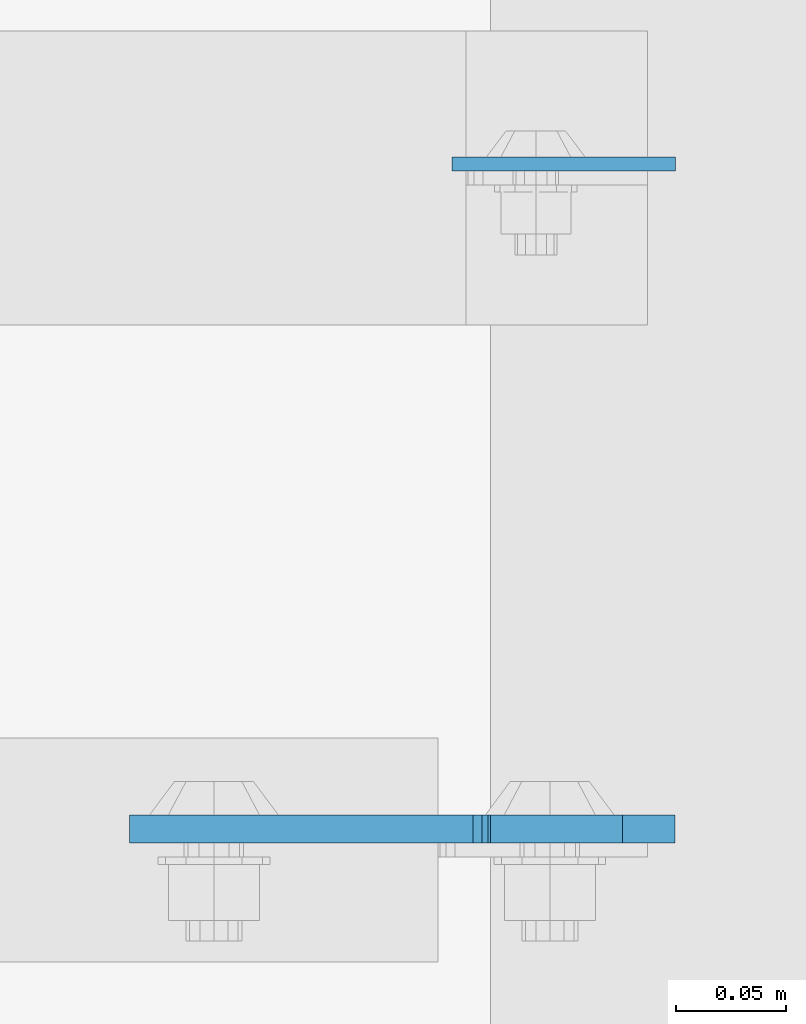
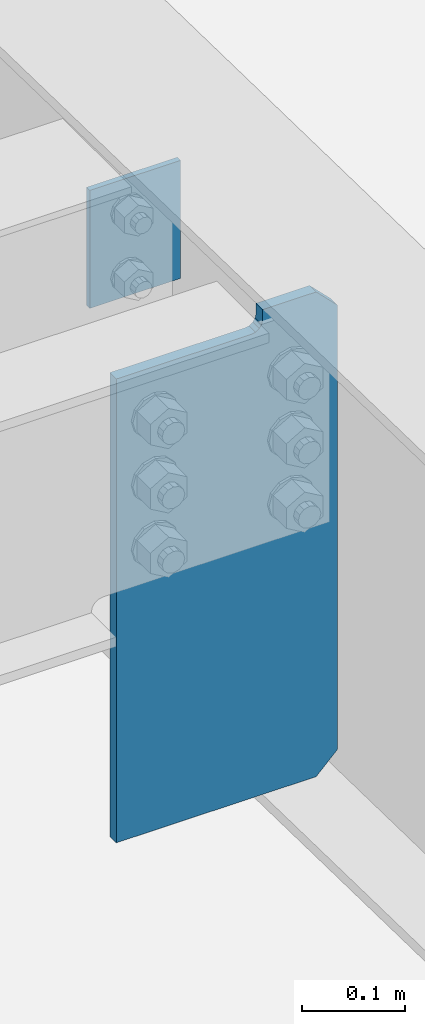
# One storey, part 1441 of 1763: 2 plates, 1 element without a shape of its own.
"""IFC2X3 building model written with IfcOpenShell, lengths in millimetres."""

from ifc_helpers import new_model, si_unit, frame, origin_with_axes, place, context, subcontext, project, spatial, faceted_brep, material, type_object, element, aggregate, save


model = new_model("IFC2X3")

# Units and contexts
model_context = context("Model", 3, precision=1e-05, world=origin_with_axes())
body_context = subcontext(model_context, "Body", "Model", "MODEL_VIEW")
ifc_project = project(units=[si_unit("LENGTHUNIT", "METRE", prefix="MILLI"), si_unit("AREAUNIT", "SQUARE_METRE"), si_unit("VOLUMEUNIT", "CUBIC_METRE"), si_unit("MASSUNIT", "GRAM", prefix="KILO"), si_unit("TIMEUNIT", "SECOND"), si_unit("PLANEANGLEUNIT", "RADIAN"), si_unit("SOLIDANGLEUNIT", "STERADIAN"), si_unit("THERMODYNAMICTEMPERATUREUNIT", "DEGREE_CELSIUS"), si_unit("LUMINOUSINTENSITYUNIT", "LUMEN")], contexts=[model_context])

# Site, building, storey
site_placement = place(None, origin_with_axes())
site = spatial("IfcSite", under=ifc_project, at=site_placement, CompositionType="ELEMENT")
building_placement = place(site_placement, origin_with_axes())
building = spatial("IfcBuilding", under=site, at=building_placement, Name="Undefined", CompositionType="ELEMENT")
storey_placement = place(building_placement, origin_with_axes())
storey = spatial("IfcBuildingStorey", under=building, at=storey_placement, Name="Undefined", CompositionType="ELEMENT", Elevation=0.0)

# Assembly, plates
assembly_placement = place(storey_placement, origin_with_axes())
assembly = element("IfcElementAssembly", 1, at=assembly_placement, inside=storey, Name="BEAM", AssemblyPlace="NOTDEFINED", PredefinedType="RIGID_FRAME")
ifc_material_1 = material(Name="STEEL/A36")
plate_type_1 = type_object("IfcPlateType", PredefinedType="NOTDEFINED")
plate_1_placement = place(assembly_placement, frame((-81001.1712022698, 9607.55000000002, 11672.7824111605), z_axis=(-1.0, 0.0, 0.0), x_axis=(0.0, 0.0, -1.0)))
plate_1 = element("IfcPlate", 2, at=plate_1_placement, type_object=plate_type_1, material=ifc_material_1, Name="PLATE", context=body_context, shape_type="Brep", body=[
    faceted_brep([(1.81898940354586e-12, -3.17500000000291, 0.0), (0.0, -3.17499999999927, 101.599998474121), (0.0, 3.17499999999927, 101.599998474121), (-1.81898940354586e-12, 3.17499999997381, 0.0), (139.699996948242, -3.17499999999927, 101.599998474121), (139.699996948242, 3.17499999999927, 101.599998474121), (139.699996948242, -3.17499999999927, 0.0), (139.699996948242, 3.17499999999927, 0.0)], [[[0, 1, 2, 3]], [[1, 4, 5, 2]], [[4, 6, 7, 5]], [[6, 0, 3, 7]], [[5, 7, 3, 2]], [[6, 4, 1, 0]]]),
])
ifc_material_2 = material(Name="STEEL/A572-50")
plate_type_2 = type_object("IfcPlateType", PredefinedType="NOTDEFINED")
plate_2_placement = place(assembly_placement, frame((-81001.4712022698, 9305.925, 11136.3348158675), z_axis=(0.0, 0.0, 1.0), x_axis=(-1.0, 0.0, 0.0)))
plate_2 = element("IfcPlate", 3, at=plate_2_placement, type_object=plate_type_2, material=ifc_material_2, Name="PLATE", context=body_context, shape_type="Brep", body=[
    faceted_brep([(83.8374938964844, -6.35000000000036, 573.93505859375), (83.8374938964844, -6.35000000000036, 561.869720450019), (83.8374938964844, 6.35000000000036, 561.869720450019), (83.8374938964844, 6.35000000000036, 573.93505859375), (84.8042238190683, -6.35000000000036, 557.009640931972), (84.8042238190683, 6.35000000000036, 557.009640931972), (87.5572377195494, -6.35000000000036, 552.889464463819), (87.5572377195494, 6.35000000000036, 552.889464463819), (91.6774141877104, -6.35000000000036, 550.136450563341), (91.6774141877104, 6.35000000000036, 550.136450563341), (96.5374937057495, -6.35000000000036, 549.169720640753), (96.5374937057495, 6.35000000000036, 549.169720640753), (247.649993896484, -6.35000000000036, 549.169720640753), (247.649993896484, 6.35000000000036, 549.169720640753), (0.0, -6.35000000000036, 550.12255859375), (23.8125, -6.35000000000036, 573.93505859375), (23.8125, 6.35000000000036, 573.93505859375), (0.0, 6.35000000000036, 550.12255859375), (0.0, -6.35000000000036, 23.8125), (0.0, 6.35000000000036, 23.8125), (23.8125, -6.35000000000036, 0.0), (23.8125, 6.35000000000036, 0.0), (247.649993896484, -6.34999999999854, 0.0), (247.649993896484, 6.34999999999854, 0.0)], [[[0, 1, 2, 3]], [[4, 5, 2, 1]], [[6, 7, 5, 4]], [[8, 9, 7, 6]], [[10, 11, 9, 8]], [[12, 13, 11, 10]], [[14, 15, 16, 17]], [[18, 14, 17, 19]], [[20, 18, 19, 21]], [[22, 20, 21, 23]], [[8, 6, 4, 1, 0, 15, 14, 18, 20, 22, 12, 10]], [[16, 15, 0, 3]], [[23, 21, 19, 17, 16, 3, 2, 5, 7, 9, 11, 13]], [[22, 23, 13, 12]]]),
])
aggregate(assembly, [plate_2, plate_1])

save(model, "model.ifc")
